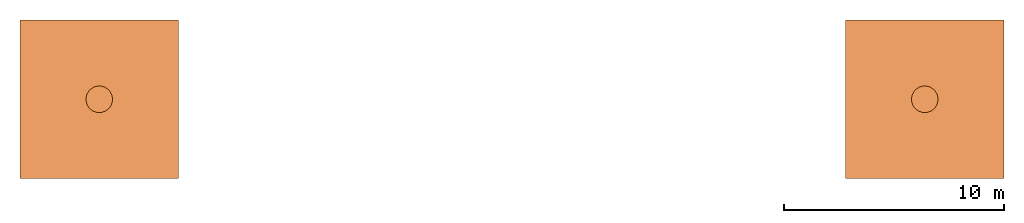
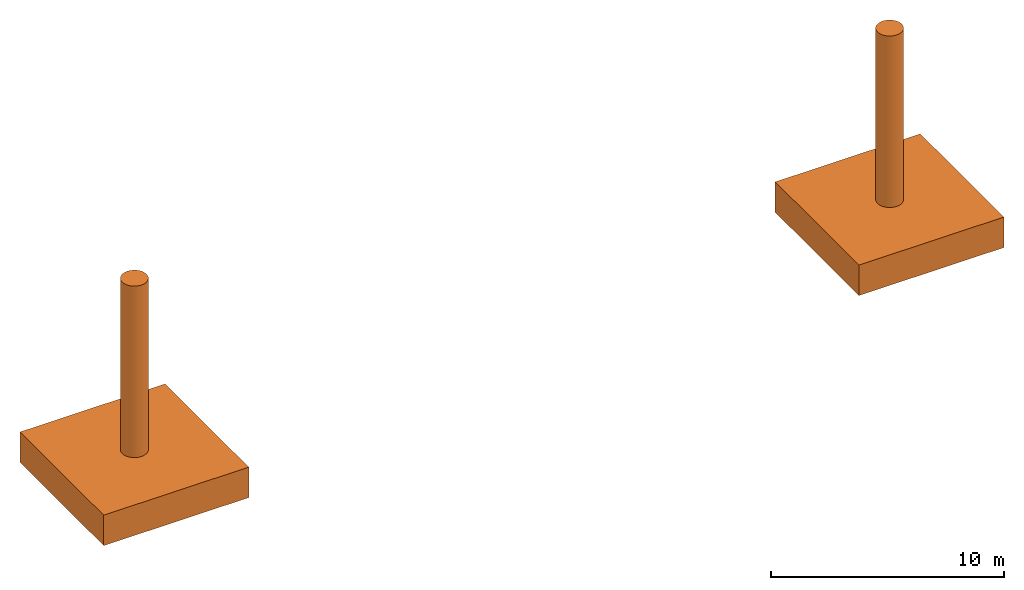
# One storey: 2 proxies.
"""IFC2X3 building model written with IfcOpenShell, lengths in metres."""

from ifc_helpers import new_model, entity, si_unit, converted_unit, derived_unit, direction, frame, frame_2d, origin, place, context, subcontext, project, spatial, polyline, circle_curve, parameter, trimmed, segment, composite_curve, rectangle, outline, extrude, source, transform, mapped, type_object, type_shapes, element, save


model = new_model("IFC2X3")

# Units and contexts
model_context = context("Model", 3, precision=1e-05, world=origin(), true_north=direction((6.12303176911189e-17, 1.0)))
body_context = subcontext(model_context, "Body", "Model", "MODEL_VIEW")
ifc_project = project(units=[si_unit("LENGTHUNIT", "METRE"), si_unit("AREAUNIT", "SQUARE_METRE"), si_unit("VOLUMEUNIT", "CUBIC_METRE"), converted_unit("PLANEANGLEUNIT", "DEGREE", entity("IfcRatioMeasure", 0.0174532925199433), si_unit("PLANEANGLEUNIT", "RADIAN"), dimensions=[0, 0, 0, 0, 0, 0, 0]), si_unit("MASSUNIT", "GRAM", prefix="KILO"), derived_unit("MASSDENSITYUNIT", [(si_unit("MASSUNIT", "GRAM", prefix="KILO"), 1), (si_unit("LENGTHUNIT", "METRE"), -3)]), si_unit("TIMEUNIT", "SECOND"), si_unit("FREQUENCYUNIT", "HERTZ"), si_unit("THERMODYNAMICTEMPERATUREUNIT", "DEGREE_CELSIUS"), derived_unit("THERMALTRANSMITTANCEUNIT", [(si_unit("MASSUNIT", "GRAM", prefix="KILO"), 1), (si_unit("THERMODYNAMICTEMPERATUREUNIT", "KELVIN"), -1), (si_unit("TIMEUNIT", "SECOND"), -3)]), derived_unit("VOLUMETRICFLOWRATEUNIT", [(si_unit("LENGTHUNIT", "METRE"), 3), (si_unit("TIMEUNIT", "SECOND"), -1)]), si_unit("ELECTRICCURRENTUNIT", "AMPERE"), si_unit("ELECTRICVOLTAGEUNIT", "VOLT"), si_unit("POWERUNIT", "WATT"), si_unit("FORCEUNIT", "NEWTON", prefix="KILO"), si_unit("ILLUMINANCEUNIT", "LUX"), si_unit("LUMINOUSFLUXUNIT", "LUMEN"), si_unit("LUMINOUSINTENSITYUNIT", "CANDELA"), derived_unit("USERDEFINED", [(si_unit("MASSUNIT", "GRAM", prefix="KILO"), -1), (si_unit("LENGTHUNIT", "METRE"), -2), (si_unit("TIMEUNIT", "SECOND"), 3), (si_unit("LUMINOUSFLUXUNIT", "LUMEN"), 1)]), derived_unit("LINEARVELOCITYUNIT", [(si_unit("LENGTHUNIT", "METRE"), 1), (si_unit("TIMEUNIT", "SECOND"), -1)]), si_unit("PRESSUREUNIT", "PASCAL"), derived_unit("USERDEFINED", [(si_unit("LENGTHUNIT", "METRE"), -2), (si_unit("MASSUNIT", "GRAM", prefix="KILO"), 1), (si_unit("TIMEUNIT", "SECOND"), -2)])], contexts=[model_context])

# Site, building, storey
site_placement = place(None, origin())
site = spatial("IfcSite", under=ifc_project, at=site_placement, CompositionType="ELEMENT")
building_placement = place(site_placement, origin())
building = spatial("IfcBuilding", under=site, at=building_placement, CompositionType="ELEMENT")
storey_placement = place(building_placement, origin())
storey = spatial("IfcBuildingStorey", under=building, at=storey_placement, Name="Nivel 1", CompositionType="ELEMENT", Elevation=0.0)

# Proxies
building_element_proxy_type = type_object("IfcBuildingElementProxyType", PredefinedType="NOTDEFINED")
shared_shape = source(origin(), body_context, "Body", "SweptSolid", [
    extrude(rectangle(XDim=7.2, YDim=7.202, at=frame_2d((0.0, 2.22044604925031e-16), x_axis=(1.0, 0.0))), frame((0.0, 0.0, -12.5)), (0.0, 0.0, 1.0), 1.6),
    extrude(outline(composite_curve([segment(trimmed(circle_curve(frame_2d((0.000999999999998927, 0.0), x_axis=(1.0, 0.0)), 0.6), [parameter(270.0)], [parameter(89.9999999999995)], True, "PARAMETER"), True, "CONTINUOUS"), segment(polyline([(0.00100000000000514, 0.6), (-0.001000000000003, 0.6)]), True, "CONTINUOUS"), segment(trimmed(circle_curve(frame_2d((-0.00100000000000101, 0.0), x_axis=(-1.0, 0.0)), 0.6), [parameter(270.0)], [parameter(89.9999999999999)], True, "PARAMETER"), True, "CONTINUOUS"), segment(polyline([(-0.00100000000000107, -0.6), (0.000999999999998927, -0.6)]), True, "CONTINUOUS")], self_intersect=False)), frame((0.0, 0.0, -10.9), z_axis=(0.0, 0.0, 1.0), x_axis=(0.0, -1.0, 0.0)), (0.0, 0.0, 1.0), 9.0),
])
type_shapes(building_element_proxy_type, [shared_shape])
for number, where in (
    (1, (20.55, 0.0, 0.449198892110017)),
    (2, (58.05, 0.0, 0.449198892110017)),
):
    element("IfcBuildingElementProxy", number, at=place(storey_placement, frame(where)), inside=storey, type_object=building_element_proxy_type, context=body_context, shape_type="MappedRepresentation", body=[
        mapped(shared_shape, transform((0.0, 0.0, 0.0), scale=1.0)),
    ])

save(model, "model.ifc")
